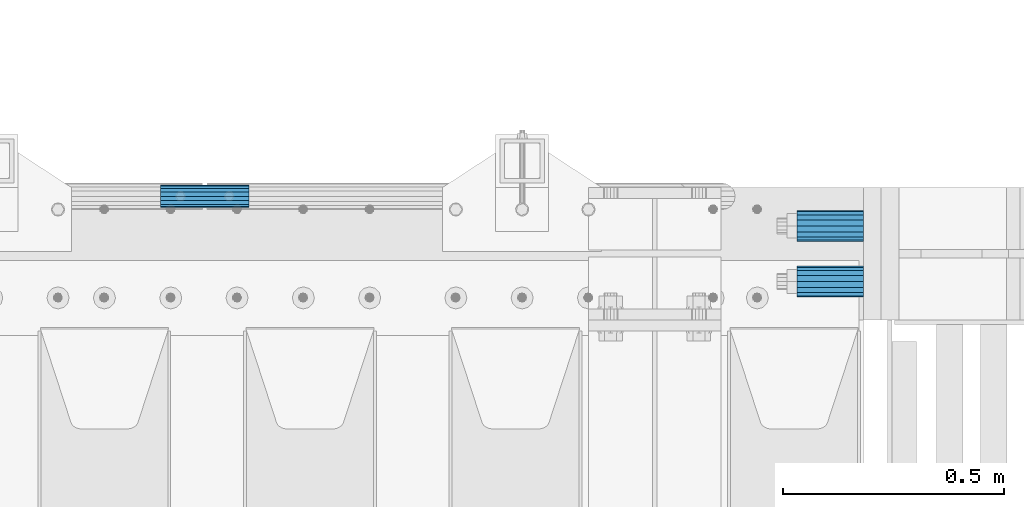
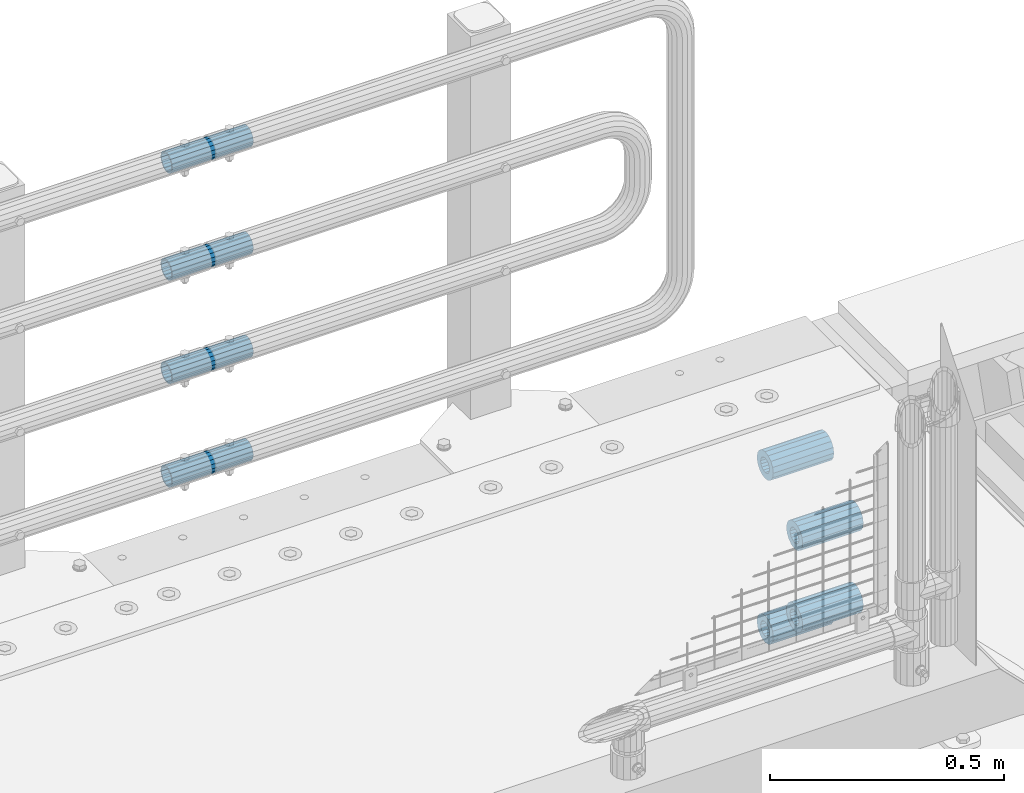
# One storey, part 174 of 247: 8 beams.
"""IFC2X3 building model written with IfcOpenShell, lengths in millimetres."""

from ifc_helpers import new_model, si_unit, frame, origin_with_axes, place, context, subcontext, project, spatial, faceted_brep, material, type_object, element, save


model = new_model("IFC2X3")

# Units and contexts
model_context = context("Model", 3, precision=1e-05, world=origin_with_axes())
body_context = subcontext(model_context, "Body", "Model", "MODEL_VIEW")
ifc_project = project(units=[si_unit("LENGTHUNIT", "METRE", prefix="MILLI"), si_unit("AREAUNIT", "SQUARE_METRE"), si_unit("VOLUMEUNIT", "CUBIC_METRE"), si_unit("MASSUNIT", "GRAM", prefix="KILO"), si_unit("TIMEUNIT", "SECOND"), si_unit("PLANEANGLEUNIT", "RADIAN"), si_unit("SOLIDANGLEUNIT", "STERADIAN"), si_unit("THERMODYNAMICTEMPERATUREUNIT", "DEGREE_CELSIUS"), si_unit("LUMINOUSINTENSITYUNIT", "LUMEN")], contexts=[model_context])

# Site, building, storey
site_placement = place(None, origin_with_axes())
site = spatial("IfcSite", under=ifc_project, at=site_placement, CompositionType="ELEMENT")
building_placement = place(site_placement, origin_with_axes())
building = spatial("IfcBuilding", under=site, at=building_placement, Name="Standard", CompositionType="ELEMENT")
storey_placement = place(building_placement, origin_with_axes())
storey = spatial("IfcBuildingStorey", under=building, at=storey_placement, Name="Undefined", CompositionType="ELEMENT", Elevation=0.0)

# Beams
ifc_material = material()
beam_type_1 = type_object("IfcBeamType", PredefinedType="NOTDEFINED")
beam_1_placement = place(storey_placement, frame((16667.0, 8937.0, -606.0), z_axis=(0.0, 0.0, 1.0), x_axis=(1.0, 0.0, 0.0)))
element("IfcBeam", 1, at=beam_1_placement, inside=storey, type_object=beam_type_1, material=ifc_material, context=body_context, shape_type="Brep", body=[
    faceted_brep([(-1.3120632047503e-07, -18.9999999995497, -6.27005647402257e-09), (0.0, -17.5537111177146, 7.27098521493672), (150.0, -17.5537111177146, 7.27098521493672), (150.0, -19.0, 0.0), (0.0, -13.4350288425444, 13.4350288425444), (150.0, -13.4350288425444, 13.4350288425444), (0.0, -7.2709852149369, 17.5537111177144), (150.0, -7.2709852149369, 17.5537111177144), (-6.3396328187082e-09, 4.50427251053043e-10, 18.9999999937299), (150.0, 0.0, 19.0), (0.0, 7.2709852149369, 17.5537111177144), (150.0, 7.2709852149369, 17.5537111177144), (0.0, 13.4350288425444, 13.4350288425444), (150.0, 13.4350288425444, 13.4350288425444), (0.0, 17.5537111177146, 7.2709852149367), (150.0, 17.5537111177146, 7.2709852149367), (1.33208573060983e-07, 19.0000000004504, -6.27005647402257e-09), (150.0, 19.0, 0.0), (0.0, 17.5537111177146, -7.2709852149367), (150.0, 17.5537111177146, -7.2709852149367), (0.0, 13.4350288425444, -13.4350288425444), (150.0, 13.4350288425444, -13.4350288425444), (0.0, 7.2709852149369, -17.5537111177144), (150.0, 7.2709852149369, -17.5537111177144), (8.3418854046613e-09, 4.50427251053043e-10, -19.0000000062682), (150.0, 0.0, -19.0), (0.0, -7.2709852149369, -17.5537111177144), (150.0, -7.2709852149369, -17.5537111177144), (0.0, -13.4350288425444, -13.4350288425444), (150.0, -13.4350288425444, -13.4350288425444), (0.0, -17.5537111177146, -7.2709852149367), (150.0, -17.5537111177146, -7.2709852149367), (0.0, -35.0, 0.0), (0.0, -32.335783637895, -13.3939201327782), (150.0, -32.335783637895, -13.3939201327782), (150.0, -35.0, 0.0), (0.0, -24.7487373415292, -24.7487373415291), (150.0, -24.7487373415293, -24.7487373415292), (0.0, -13.3939201327781, -32.335783637895), (150.0, -13.393920132778, -32.335783637895), (0.0, 0.0, -35.0000000000001), (150.0, 0.0, -35.0), (0.0, 13.3939201327782, -32.335783637895), (150.0, 13.393920132778, -32.335783637895), (0.0, 24.7487373415292, -24.7487373415291), (150.0, 24.7487373415293, -24.7487373415292), (0.0, 32.335783637895, -13.3939201327782), (150.0, 32.335783637895, -13.3939201327781), (0.0, 35.0, 0.0), (150.0, 35.0, 0.0), (0.0, 32.335783637895, 13.3939201327781), (150.0, 32.335783637895, 13.3939201327781), (0.0, 24.7487373415292, 24.748737341529), (150.0, 24.7487373415293, 24.7487373415292), (0.0, 13.3939201327781, 32.335783637895), (150.0, 13.393920132778, 32.335783637895), (0.0, 0.0, 35.0), (150.0, 0.0, 35.0), (0.0, -13.3939201327781, 32.335783637895), (150.0, -13.393920132778, 32.335783637895), (0.0, -24.7487373415292, 24.748737341529), (150.0, -24.7487373415293, 24.7487373415292), (0.0, -32.335783637895, 13.3939201327781), (150.0, -32.335783637895, 13.3939201327781)], [[[0, 1, 2, 3]], [[1, 4, 5, 2]], [[4, 6, 7, 5]], [[6, 8, 9, 7]], [[8, 10, 11, 9]], [[10, 12, 13, 11]], [[12, 14, 15, 13]], [[14, 16, 17, 15]], [[16, 18, 19, 17]], [[18, 20, 21, 19]], [[20, 22, 23, 21]], [[22, 24, 25, 23]], [[24, 26, 27, 25]], [[26, 28, 29, 27]], [[28, 30, 31, 29]], [[30, 0, 3, 31]], [[32, 33, 34, 35]], [[33, 36, 37, 34]], [[36, 38, 39, 37]], [[38, 40, 41, 39]], [[40, 42, 43, 41]], [[42, 44, 45, 43]], [[44, 46, 47, 45]], [[46, 48, 49, 47]], [[48, 50, 51, 49]], [[50, 52, 53, 51]], [[52, 54, 55, 53]], [[54, 56, 57, 55]], [[56, 58, 59, 57]], [[58, 60, 61, 59]], [[60, 62, 63, 61]], [[62, 32, 35, 63]], [[37, 39, 41, 43, 45, 47, 49, 51, 53, 55, 57, 59, 61, 63, 35, 34], [5, 7, 9, 11, 13, 15, 17, 19, 21, 23, 25, 27, 29, 31, 3, 2]], [[62, 60, 58, 56, 54, 52, 50, 48, 46, 44, 42, 40, 38, 36, 33, 32], [30, 28, 26, 24, 22, 20, 18, 16, 14, 12, 10, 8, 6, 4, 1, 0]]]),
])
beam_2_placement = place(storey_placement, frame((16667.0, 8937.0, -392.0), z_axis=(0.0, 0.0, 1.0), x_axis=(1.0, 0.0, 0.0)))
element("IfcBeam", 2, at=beam_2_placement, inside=storey, type_object=beam_type_1, material=ifc_material, context=body_context, shape_type="Brep", body=[
    faceted_brep([(-1.3120632047503e-07, -18.9999999995497, -6.27005647402257e-09), (0.0, -17.5537111177146, 7.27098521493672), (150.0, -17.5537111177146, 7.27098521493672), (150.0, -19.0, 0.0), (0.0, -13.4350288425444, 13.4350288425444), (150.0, -13.4350288425444, 13.4350288425444), (0.0, -7.2709852149369, 17.5537111177144), (150.0, -7.2709852149369, 17.5537111177144), (-6.3396328187082e-09, 4.50427251053043e-10, 18.9999999937299), (150.0, 0.0, 19.0), (0.0, 7.2709852149369, 17.5537111177144), (150.0, 7.2709852149369, 17.5537111177144), (0.0, 13.4350288425444, 13.4350288425444), (150.0, 13.4350288425444, 13.4350288425444), (0.0, 17.5537111177146, 7.2709852149367), (150.0, 17.5537111177146, 7.2709852149367), (1.33208573060983e-07, 19.0000000004504, -6.27005647402257e-09), (150.0, 19.0, 0.0), (0.0, 17.5537111177146, -7.2709852149367), (150.0, 17.5537111177146, -7.2709852149367), (0.0, 13.4350288425444, -13.4350288425444), (150.0, 13.4350288425444, -13.4350288425444), (0.0, 7.2709852149369, -17.5537111177144), (150.0, 7.2709852149369, -17.5537111177144), (8.3418854046613e-09, 4.50427251053043e-10, -19.0000000062682), (150.0, 0.0, -19.0), (0.0, -7.2709852149369, -17.5537111177144), (150.0, -7.2709852149369, -17.5537111177144), (0.0, -13.4350288425444, -13.4350288425444), (150.0, -13.4350288425444, -13.4350288425444), (0.0, -17.5537111177146, -7.2709852149367), (150.0, -17.5537111177146, -7.2709852149367), (0.0, -35.0, 0.0), (0.0, -32.335783637895, -13.3939201327782), (150.0, -32.335783637895, -13.3939201327782), (150.0, -35.0, 0.0), (0.0, -24.7487373415292, -24.7487373415291), (150.0, -24.7487373415293, -24.7487373415292), (0.0, -13.3939201327781, -32.335783637895), (150.0, -13.393920132778, -32.335783637895), (0.0, 0.0, -35.0000000000001), (150.0, 0.0, -35.0), (0.0, 13.3939201327782, -32.335783637895), (150.0, 13.393920132778, -32.335783637895), (0.0, 24.7487373415292, -24.7487373415291), (150.0, 24.7487373415293, -24.7487373415292), (0.0, 32.335783637895, -13.3939201327782), (150.0, 32.335783637895, -13.3939201327781), (0.0, 35.0, 0.0), (150.0, 35.0, 0.0), (0.0, 32.335783637895, 13.3939201327781), (150.0, 32.335783637895, 13.3939201327781), (0.0, 24.7487373415292, 24.748737341529), (150.0, 24.7487373415293, 24.7487373415292), (0.0, 13.3939201327781, 32.335783637895), (150.0, 13.393920132778, 32.335783637895), (0.0, 0.0, 35.0), (150.0, 0.0, 35.0), (0.0, -13.3939201327781, 32.335783637895), (150.0, -13.393920132778, 32.335783637895), (0.0, -24.7487373415292, 24.748737341529), (150.0, -24.7487373415293, 24.7487373415292), (0.0, -32.335783637895, 13.3939201327781), (150.0, -32.335783637895, 13.3939201327781)], [[[0, 1, 2, 3]], [[1, 4, 5, 2]], [[4, 6, 7, 5]], [[6, 8, 9, 7]], [[8, 10, 11, 9]], [[10, 12, 13, 11]], [[12, 14, 15, 13]], [[14, 16, 17, 15]], [[16, 18, 19, 17]], [[18, 20, 21, 19]], [[20, 22, 23, 21]], [[22, 24, 25, 23]], [[24, 26, 27, 25]], [[26, 28, 29, 27]], [[28, 30, 31, 29]], [[30, 0, 3, 31]], [[32, 33, 34, 35]], [[33, 36, 37, 34]], [[36, 38, 39, 37]], [[38, 40, 41, 39]], [[40, 42, 43, 41]], [[42, 44, 45, 43]], [[44, 46, 47, 45]], [[46, 48, 49, 47]], [[48, 50, 51, 49]], [[50, 52, 53, 51]], [[52, 54, 55, 53]], [[54, 56, 57, 55]], [[56, 58, 59, 57]], [[58, 60, 61, 59]], [[60, 62, 63, 61]], [[62, 32, 35, 63]], [[37, 39, 41, 43, 45, 47, 49, 51, 53, 55, 57, 59, 61, 63, 35, 34], [5, 7, 9, 11, 13, 15, 17, 19, 21, 23, 25, 27, 29, 31, 3, 2]], [[62, 60, 58, 56, 54, 52, 50, 48, 46, 44, 42, 40, 38, 36, 33, 32], [30, 28, 26, 24, 22, 20, 18, 16, 14, 12, 10, 8, 6, 4, 1, 0]]]),
])
beam_3_placement = place(storey_placement, frame((16667.0, 9063.0, -285.0), z_axis=(0.0, 0.0, 1.0), x_axis=(1.0, 0.0, 0.0)))
element("IfcBeam", 3, at=beam_3_placement, inside=storey, type_object=beam_type_1, material=ifc_material, context=body_context, shape_type="Brep", body=[
    faceted_brep([(-1.3120632047503e-07, -18.9999999995497, -6.27005647402257e-09), (0.0, -17.5537111177146, 7.27098521493672), (150.0, -17.5537111177146, 7.27098521493672), (150.0, -19.0, 0.0), (0.0, -13.4350288425444, 13.4350288425444), (150.0, -13.4350288425444, 13.4350288425444), (0.0, -7.2709852149369, 17.5537111177144), (150.0, -7.2709852149369, 17.5537111177144), (-6.3396328187082e-09, 4.50427251053043e-10, 18.9999999937299), (150.0, 0.0, 19.0), (0.0, 7.2709852149369, 17.5537111177144), (150.0, 7.2709852149369, 17.5537111177144), (0.0, 13.4350288425444, 13.4350288425444), (150.0, 13.4350288425444, 13.4350288425444), (0.0, 17.5537111177146, 7.2709852149367), (150.0, 17.5537111177146, 7.2709852149367), (1.33208573060983e-07, 19.0000000004504, -6.27005647402257e-09), (150.0, 19.0, 0.0), (0.0, 17.5537111177146, -7.2709852149367), (150.0, 17.5537111177146, -7.2709852149367), (0.0, 13.4350288425444, -13.4350288425444), (150.0, 13.4350288425444, -13.4350288425444), (0.0, 7.2709852149369, -17.5537111177144), (150.0, 7.2709852149369, -17.5537111177144), (8.3418854046613e-09, 4.50427251053043e-10, -19.0000000062682), (150.0, 0.0, -19.0), (0.0, -7.2709852149369, -17.5537111177144), (150.0, -7.2709852149369, -17.5537111177144), (0.0, -13.4350288425444, -13.4350288425444), (150.0, -13.4350288425444, -13.4350288425444), (0.0, -17.5537111177146, -7.2709852149367), (150.0, -17.5537111177146, -7.2709852149367), (0.0, -35.0, 0.0), (0.0, -32.335783637895, -13.3939201327782), (150.0, -32.335783637895, -13.3939201327782), (150.0, -35.0, 0.0), (0.0, -24.7487373415292, -24.7487373415291), (150.0, -24.7487373415293, -24.7487373415292), (0.0, -13.3939201327781, -32.335783637895), (150.0, -13.393920132778, -32.335783637895), (0.0, 0.0, -35.0000000000001), (150.0, 0.0, -35.0), (0.0, 13.3939201327782, -32.335783637895), (150.0, 13.393920132778, -32.335783637895), (0.0, 24.7487373415292, -24.7487373415291), (150.0, 24.7487373415293, -24.7487373415292), (0.0, 32.335783637895, -13.3939201327782), (150.0, 32.335783637895, -13.3939201327781), (0.0, 35.0, 0.0), (150.0, 35.0, 0.0), (0.0, 32.335783637895, 13.3939201327781), (150.0, 32.335783637895, 13.3939201327781), (0.0, 24.7487373415292, 24.748737341529), (150.0, 24.7487373415293, 24.7487373415292), (0.0, 13.3939201327781, 32.335783637895), (150.0, 13.393920132778, 32.335783637895), (0.0, 0.0, 35.0), (150.0, 0.0, 35.0), (0.0, -13.3939201327781, 32.335783637895), (150.0, -13.393920132778, 32.335783637895), (0.0, -24.7487373415292, 24.748737341529), (150.0, -24.7487373415293, 24.7487373415292), (0.0, -32.335783637895, 13.3939201327781), (150.0, -32.335783637895, 13.3939201327781)], [[[0, 1, 2, 3]], [[1, 4, 5, 2]], [[4, 6, 7, 5]], [[6, 8, 9, 7]], [[8, 10, 11, 9]], [[10, 12, 13, 11]], [[12, 14, 15, 13]], [[14, 16, 17, 15]], [[16, 18, 19, 17]], [[18, 20, 21, 19]], [[20, 22, 23, 21]], [[22, 24, 25, 23]], [[24, 26, 27, 25]], [[26, 28, 29, 27]], [[28, 30, 31, 29]], [[30, 0, 3, 31]], [[32, 33, 34, 35]], [[33, 36, 37, 34]], [[36, 38, 39, 37]], [[38, 40, 41, 39]], [[40, 42, 43, 41]], [[42, 44, 45, 43]], [[44, 46, 47, 45]], [[46, 48, 49, 47]], [[48, 50, 51, 49]], [[50, 52, 53, 51]], [[52, 54, 55, 53]], [[54, 56, 57, 55]], [[56, 58, 59, 57]], [[58, 60, 61, 59]], [[60, 62, 63, 61]], [[62, 32, 35, 63]], [[37, 39, 41, 43, 45, 47, 49, 51, 53, 55, 57, 59, 61, 63, 35, 34], [5, 7, 9, 11, 13, 15, 17, 19, 21, 23, 25, 27, 29, 31, 3, 2]], [[62, 60, 58, 56, 54, 52, 50, 48, 46, 44, 42, 40, 38, 36, 33, 32], [30, 28, 26, 24, 22, 20, 18, 16, 14, 12, 10, 8, 6, 4, 1, 0]]]),
])
beam_4_placement = place(storey_placement, frame((16667.0, 9063.0, -713.0), z_axis=(0.0, 0.0, 1.0), x_axis=(1.0, 0.0, 0.0)))
element("IfcBeam", 4, at=beam_4_placement, inside=storey, type_object=beam_type_1, material=ifc_material, context=body_context, shape_type="Brep", body=[
    faceted_brep([(-1.3120632047503e-07, -18.9999999995497, -6.27005647402257e-09), (0.0, -17.5537111177146, 7.27098521493672), (150.0, -17.5537111177146, 7.27098521493672), (150.0, -19.0, 0.0), (0.0, -13.4350288425444, 13.4350288425444), (150.0, -13.4350288425444, 13.4350288425444), (0.0, -7.2709852149369, 17.5537111177144), (150.0, -7.2709852149369, 17.5537111177144), (-6.3396328187082e-09, 4.50427251053043e-10, 18.9999999937299), (150.0, 0.0, 19.0), (0.0, 7.2709852149369, 17.5537111177144), (150.0, 7.2709852149369, 17.5537111177144), (0.0, 13.4350288425444, 13.4350288425444), (150.0, 13.4350288425444, 13.4350288425444), (0.0, 17.5537111177146, 7.2709852149367), (150.0, 17.5537111177146, 7.2709852149367), (1.33208573060983e-07, 19.0000000004504, -6.27005647402257e-09), (150.0, 19.0, 0.0), (0.0, 17.5537111177146, -7.2709852149367), (150.0, 17.5537111177146, -7.2709852149367), (0.0, 13.4350288425444, -13.4350288425444), (150.0, 13.4350288425444, -13.4350288425444), (0.0, 7.2709852149369, -17.5537111177144), (150.0, 7.2709852149369, -17.5537111177144), (8.3418854046613e-09, 4.50427251053043e-10, -19.0000000062682), (150.0, 0.0, -19.0), (0.0, -7.2709852149369, -17.5537111177144), (150.0, -7.2709852149369, -17.5537111177144), (0.0, -13.4350288425444, -13.4350288425444), (150.0, -13.4350288425444, -13.4350288425444), (0.0, -17.5537111177146, -7.2709852149367), (150.0, -17.5537111177146, -7.2709852149367), (0.0, -35.0, 0.0), (0.0, -32.335783637895, -13.3939201327782), (150.0, -32.335783637895, -13.3939201327782), (150.0, -35.0, 0.0), (0.0, -24.7487373415292, -24.7487373415291), (150.0, -24.7487373415293, -24.7487373415292), (0.0, -13.3939201327781, -32.335783637895), (150.0, -13.393920132778, -32.335783637895), (0.0, 0.0, -35.0000000000001), (150.0, 0.0, -35.0), (0.0, 13.3939201327782, -32.335783637895), (150.0, 13.393920132778, -32.335783637895), (0.0, 24.7487373415292, -24.7487373415291), (150.0, 24.7487373415293, -24.7487373415292), (0.0, 32.335783637895, -13.3939201327782), (150.0, 32.335783637895, -13.3939201327781), (0.0, 35.0, 0.0), (150.0, 35.0, 0.0), (0.0, 32.335783637895, 13.3939201327781), (150.0, 32.335783637895, 13.3939201327781), (0.0, 24.7487373415292, 24.748737341529), (150.0, 24.7487373415293, 24.7487373415292), (0.0, 13.3939201327781, 32.335783637895), (150.0, 13.393920132778, 32.335783637895), (0.0, 0.0, 35.0), (150.0, 0.0, 35.0), (0.0, -13.3939201327781, 32.335783637895), (150.0, -13.393920132778, 32.335783637895), (0.0, -24.7487373415292, 24.748737341529), (150.0, -24.7487373415293, 24.7487373415292), (0.0, -32.335783637895, 13.3939201327781), (150.0, -32.335783637895, 13.3939201327781)], [[[0, 1, 2, 3]], [[1, 4, 5, 2]], [[4, 6, 7, 5]], [[6, 8, 9, 7]], [[8, 10, 11, 9]], [[10, 12, 13, 11]], [[12, 14, 15, 13]], [[14, 16, 17, 15]], [[16, 18, 19, 17]], [[18, 20, 21, 19]], [[20, 22, 23, 21]], [[22, 24, 25, 23]], [[24, 26, 27, 25]], [[26, 28, 29, 27]], [[28, 30, 31, 29]], [[30, 0, 3, 31]], [[32, 33, 34, 35]], [[33, 36, 37, 34]], [[36, 38, 39, 37]], [[38, 40, 41, 39]], [[40, 42, 43, 41]], [[42, 44, 45, 43]], [[44, 46, 47, 45]], [[46, 48, 49, 47]], [[48, 50, 51, 49]], [[50, 52, 53, 51]], [[52, 54, 55, 53]], [[54, 56, 57, 55]], [[56, 58, 59, 57]], [[58, 60, 61, 59]], [[60, 62, 63, 61]], [[62, 32, 35, 63]], [[37, 39, 41, 43, 45, 47, 49, 51, 53, 55, 57, 59, 61, 63, 35, 34], [5, 7, 9, 11, 13, 15, 17, 19, 21, 23, 25, 27, 29, 31, 3, 2]], [[62, 60, 58, 56, 54, 52, 50, 48, 46, 44, 42, 40, 38, 36, 33, 32], [30, 28, 26, 24, 22, 20, 18, 16, 14, 12, 10, 8, 6, 4, 1, 0]]]),
])
beam_type_2 = type_object("IfcBeamType", PredefinedType="NOTDEFINED")
beam_5_placement = place(storey_placement, frame((15226.9975029999, 9129.8500000004, 419.849999999725), z_axis=(0.0, 0.0, 1.0), x_axis=(1.0, 0.0, 0.0)))
element("IfcBeam", 5, at=beam_5_placement, inside=storey, type_object=beam_type_2, material=ifc_material, context=body_context, shape_type="Brep", body=[
    faceted_brep([(0.0, -21.8999999999996, 0.0), (0.0, -20.232961761998, 8.38076716879547), (200.0, -20.232961761998, 8.38076716879547), (200.0, -21.8999999999996, 0.0), (0.0, -15.4856385079856, 15.4856385079854), (200.0, -15.4856385079856, 15.4856385079854), (0.0, -8.3807671687955, 20.2329617619972), (200.0, -8.3807671687955, 20.2329617619972), (0.0, 0.0, 21.9), (200.0, 0.0, 21.9), (0.0, 8.3807671687955, 20.2329617619972), (200.0, 8.3807671687955, 20.2329617619972), (0.0, 15.4856385079856, 15.4856385079854), (200.0, 15.4856385079856, 15.4856385079854), (0.0, 20.232961761998, 8.38076716879547), (200.0, 20.232961761998, 8.38076716879547), (0.0, 21.8999999999996, 0.0), (200.0, 21.8999999999996, 0.0), (0.0, 20.232961761998, -8.38076716879547), (200.0, 20.232961761998, -8.38076716879547), (0.0, 15.4856385079856, -15.4856385079854), (200.0, 15.4856385079856, -15.4856385079854), (0.0, 8.3807671687955, -20.2329617619972), (200.0, 8.3807671687955, -20.2329617619972), (0.0, 0.0, -21.9), (200.0, 0.0, -21.9), (0.0, -8.3807671687955, -20.2329617619972), (200.0, -8.3807671687955, -20.2329617619972), (0.0, -15.4856385079856, -15.4856385079854), (200.0, -15.4856385079856, -15.4856385079854), (0.0, -20.232961761998, -8.38076716879547), (200.0, -20.232961761998, -8.38076716879547), (0.0, -25.5, 0.0), (0.0, -23.5589280790373, -9.7584275253098), (200.0, -23.5589280790373, -9.7584275253098), (200.0, -25.5, 0.0), (0.0, -18.0312229202573, -18.031222920257), (200.0, -18.0312229202573, -18.031222920257), (0.0, -9.75842752531025, -23.5589280790378), (200.0, -9.75842752531025, -23.5589280790378), (0.0, 0.0, -25.5), (200.0, 0.0, -25.5), (0.0, 9.75842752531025, -23.5589280790378), (200.0, 9.75842752531025, -23.5589280790378), (0.0, 18.0312229202573, -18.031222920257), (200.0, 18.0312229202573, -18.031222920257), (0.0, 23.5589280790373, -9.7584275253098), (200.0, 23.5589280790373, -9.7584275253098), (0.0, 25.5, 0.0), (200.0, 25.5, 0.0), (0.0, 23.5589280790373, 9.7584275253098), (200.0, 23.5589280790373, 9.7584275253098), (0.0, 18.0312229202573, 18.031222920257), (200.0, 18.0312229202573, 18.031222920257), (0.0, 9.75842752531025, 23.5589280790378), (200.0, 9.75842752531025, 23.5589280790378), (0.0, 0.0, 25.5), (200.0, 0.0, 25.5), (0.0, -9.75842752531025, 23.5589280790378), (200.0, -9.75842752531025, 23.5589280790378), (0.0, -18.0312229202573, 18.031222920257), (200.0, -18.0312229202573, 18.031222920257), (0.0, -23.5589280790373, 9.7584275253098), (200.0, -23.5589280790373, 9.7584275253098)], [[[0, 1, 2, 3]], [[1, 4, 5, 2]], [[4, 6, 7, 5]], [[6, 8, 9, 7]], [[8, 10, 11, 9]], [[10, 12, 13, 11]], [[12, 14, 15, 13]], [[14, 16, 17, 15]], [[16, 18, 19, 17]], [[18, 20, 21, 19]], [[20, 22, 23, 21]], [[22, 24, 25, 23]], [[24, 26, 27, 25]], [[26, 28, 29, 27]], [[28, 30, 31, 29]], [[30, 0, 3, 31]], [[32, 33, 34, 35]], [[33, 36, 37, 34]], [[36, 38, 39, 37]], [[38, 40, 41, 39]], [[40, 42, 43, 41]], [[42, 44, 45, 43]], [[44, 46, 47, 45]], [[46, 48, 49, 47]], [[48, 50, 51, 49]], [[50, 52, 53, 51]], [[52, 54, 55, 53]], [[54, 56, 57, 55]], [[56, 58, 59, 57]], [[58, 60, 61, 59]], [[60, 62, 63, 61]], [[62, 32, 35, 63]], [[37, 39, 41, 43, 45, 47, 49, 51, 53, 55, 57, 59, 61, 63, 35, 34], [5, 7, 9, 11, 13, 15, 17, 19, 21, 23, 25, 27, 29, 31, 3, 2]], [[62, 60, 58, 56, 54, 52, 50, 48, 46, 44, 42, 40, 38, 36, 33, 32], [30, 28, 26, 24, 22, 20, 18, 16, 14, 12, 10, 8, 6, 4, 1, 0]]]),
])
beam_6_placement = place(storey_placement, frame((15226.9975029999, 9129.8500000004, 149.849999999725), z_axis=(0.0, 0.0, 1.0), x_axis=(1.0, 0.0, 0.0)))
element("IfcBeam", 6, at=beam_6_placement, inside=storey, type_object=beam_type_2, material=ifc_material, context=body_context, shape_type="Brep", body=[
    faceted_brep([(0.0, -21.8999999999996, 0.0), (0.0, -20.232961761998, 8.38076716879547), (200.0, -20.232961761998, 8.38076716879547), (200.0, -21.8999999999996, 0.0), (0.0, -15.4856385079856, 15.4856385079854), (200.0, -15.4856385079856, 15.4856385079854), (0.0, -8.3807671687955, 20.2329617619972), (200.0, -8.3807671687955, 20.2329617619972), (0.0, 0.0, 21.9), (200.0, 0.0, 21.9), (0.0, 8.3807671687955, 20.2329617619972), (200.0, 8.3807671687955, 20.2329617619972), (0.0, 15.4856385079856, 15.4856385079854), (200.0, 15.4856385079856, 15.4856385079854), (0.0, 20.232961761998, 8.38076716879547), (200.0, 20.232961761998, 8.38076716879547), (0.0, 21.8999999999996, 0.0), (200.0, 21.8999999999996, 0.0), (0.0, 20.232961761998, -8.38076716879547), (200.0, 20.232961761998, -8.38076716879547), (0.0, 15.4856385079856, -15.4856385079854), (200.0, 15.4856385079856, -15.4856385079854), (0.0, 8.3807671687955, -20.2329617619972), (200.0, 8.3807671687955, -20.2329617619972), (0.0, 0.0, -21.9), (200.0, 0.0, -21.9), (0.0, -8.3807671687955, -20.2329617619972), (200.0, -8.3807671687955, -20.2329617619972), (0.0, -15.4856385079856, -15.4856385079854), (200.0, -15.4856385079856, -15.4856385079854), (0.0, -20.232961761998, -8.38076716879547), (200.0, -20.232961761998, -8.38076716879547), (0.0, -25.5, 0.0), (0.0, -23.5589280790373, -9.7584275253098), (200.0, -23.5589280790373, -9.7584275253098), (200.0, -25.5, 0.0), (0.0, -18.0312229202573, -18.031222920257), (200.0, -18.0312229202573, -18.031222920257), (0.0, -9.75842752531025, -23.5589280790378), (200.0, -9.75842752531025, -23.5589280790378), (0.0, 0.0, -25.5), (200.0, 0.0, -25.5), (0.0, 9.75842752531025, -23.5589280790378), (200.0, 9.75842752531025, -23.5589280790378), (0.0, 18.0312229202573, -18.031222920257), (200.0, 18.0312229202573, -18.031222920257), (0.0, 23.5589280790373, -9.7584275253098), (200.0, 23.5589280790373, -9.7584275253098), (0.0, 25.5, 0.0), (200.0, 25.5, 0.0), (0.0, 23.5589280790373, 9.7584275253098), (200.0, 23.5589280790373, 9.7584275253098), (0.0, 18.0312229202573, 18.031222920257), (200.0, 18.0312229202573, 18.031222920257), (0.0, 9.75842752531025, 23.5589280790378), (200.0, 9.75842752531025, 23.5589280790378), (0.0, 0.0, 25.5), (200.0, 0.0, 25.5), (0.0, -9.75842752531025, 23.5589280790378), (200.0, -9.75842752531025, 23.5589280790378), (0.0, -18.0312229202573, 18.031222920257), (200.0, -18.0312229202573, 18.031222920257), (0.0, -23.5589280790373, 9.7584275253098), (200.0, -23.5589280790373, 9.7584275253098)], [[[0, 1, 2, 3]], [[1, 4, 5, 2]], [[4, 6, 7, 5]], [[6, 8, 9, 7]], [[8, 10, 11, 9]], [[10, 12, 13, 11]], [[12, 14, 15, 13]], [[14, 16, 17, 15]], [[16, 18, 19, 17]], [[18, 20, 21, 19]], [[20, 22, 23, 21]], [[22, 24, 25, 23]], [[24, 26, 27, 25]], [[26, 28, 29, 27]], [[28, 30, 31, 29]], [[30, 0, 3, 31]], [[32, 33, 34, 35]], [[33, 36, 37, 34]], [[36, 38, 39, 37]], [[38, 40, 41, 39]], [[40, 42, 43, 41]], [[42, 44, 45, 43]], [[44, 46, 47, 45]], [[46, 48, 49, 47]], [[48, 50, 51, 49]], [[50, 52, 53, 51]], [[52, 54, 55, 53]], [[54, 56, 57, 55]], [[56, 58, 59, 57]], [[58, 60, 61, 59]], [[60, 62, 63, 61]], [[62, 32, 35, 63]], [[37, 39, 41, 43, 45, 47, 49, 51, 53, 55, 57, 59, 61, 63, 35, 34], [5, 7, 9, 11, 13, 15, 17, 19, 21, 23, 25, 27, 29, 31, 3, 2]], [[62, 60, 58, 56, 54, 52, 50, 48, 46, 44, 42, 40, 38, 36, 33, 32], [30, 28, 26, 24, 22, 20, 18, 16, 14, 12, 10, 8, 6, 4, 1, 0]]]),
])
beam_7_placement = place(storey_placement, frame((15226.9975029999, 9129.8500000004, 689.849999999725), z_axis=(0.0, 0.0, 1.0), x_axis=(1.0, 0.0, 0.0)))
element("IfcBeam", 7, at=beam_7_placement, inside=storey, type_object=beam_type_2, material=ifc_material, context=body_context, shape_type="Brep", body=[
    faceted_brep([(0.0, -21.8999999999996, 0.0), (0.0, -20.232961761998, 8.38076716879547), (200.0, -20.232961761998, 8.38076716879547), (200.0, -21.8999999999996, 0.0), (0.0, -15.4856385079856, 15.4856385079854), (200.0, -15.4856385079856, 15.4856385079854), (0.0, -8.3807671687955, 20.2329617619972), (200.0, -8.3807671687955, 20.2329617619972), (0.0, 0.0, 21.9), (200.0, 0.0, 21.9), (0.0, 8.3807671687955, 20.2329617619972), (200.0, 8.3807671687955, 20.2329617619972), (0.0, 15.4856385079856, 15.4856385079854), (200.0, 15.4856385079856, 15.4856385079854), (0.0, 20.232961761998, 8.38076716879547), (200.0, 20.232961761998, 8.38076716879547), (0.0, 21.8999999999996, 0.0), (200.0, 21.8999999999996, 0.0), (0.0, 20.232961761998, -8.38076716879547), (200.0, 20.232961761998, -8.38076716879547), (0.0, 15.4856385079856, -15.4856385079854), (200.0, 15.4856385079856, -15.4856385079854), (0.0, 8.3807671687955, -20.2329617619972), (200.0, 8.3807671687955, -20.2329617619972), (0.0, 0.0, -21.9), (200.0, 0.0, -21.9), (0.0, -8.3807671687955, -20.2329617619972), (200.0, -8.3807671687955, -20.2329617619972), (0.0, -15.4856385079856, -15.4856385079854), (200.0, -15.4856385079856, -15.4856385079854), (0.0, -20.232961761998, -8.38076716879547), (200.0, -20.232961761998, -8.38076716879547), (0.0, -25.5, 0.0), (0.0, -23.5589280790373, -9.7584275253098), (200.0, -23.5589280790373, -9.7584275253098), (200.0, -25.5, 0.0), (0.0, -18.0312229202573, -18.031222920257), (200.0, -18.0312229202573, -18.031222920257), (0.0, -9.75842752531025, -23.5589280790378), (200.0, -9.75842752531025, -23.5589280790378), (0.0, 0.0, -25.5), (200.0, 0.0, -25.5), (0.0, 9.75842752531025, -23.5589280790378), (200.0, 9.75842752531025, -23.5589280790378), (0.0, 18.0312229202573, -18.031222920257), (200.0, 18.0312229202573, -18.031222920257), (0.0, 23.5589280790373, -9.7584275253098), (200.0, 23.5589280790373, -9.7584275253098), (0.0, 25.5, 0.0), (200.0, 25.5, 0.0), (0.0, 23.5589280790373, 9.7584275253098), (200.0, 23.5589280790373, 9.7584275253098), (0.0, 18.0312229202573, 18.031222920257), (200.0, 18.0312229202573, 18.031222920257), (0.0, 9.75842752531025, 23.5589280790378), (200.0, 9.75842752531025, 23.5589280790378), (0.0, 0.0, 25.5), (200.0, 0.0, 25.5), (0.0, -9.75842752531025, 23.5589280790378), (200.0, -9.75842752531025, 23.5589280790378), (0.0, -18.0312229202573, 18.031222920257), (200.0, -18.0312229202573, 18.031222920257), (0.0, -23.5589280790373, 9.7584275253098), (200.0, -23.5589280790373, 9.7584275253098)], [[[0, 1, 2, 3]], [[1, 4, 5, 2]], [[4, 6, 7, 5]], [[6, 8, 9, 7]], [[8, 10, 11, 9]], [[10, 12, 13, 11]], [[12, 14, 15, 13]], [[14, 16, 17, 15]], [[16, 18, 19, 17]], [[18, 20, 21, 19]], [[20, 22, 23, 21]], [[22, 24, 25, 23]], [[24, 26, 27, 25]], [[26, 28, 29, 27]], [[28, 30, 31, 29]], [[30, 0, 3, 31]], [[32, 33, 34, 35]], [[33, 36, 37, 34]], [[36, 38, 39, 37]], [[38, 40, 41, 39]], [[40, 42, 43, 41]], [[42, 44, 45, 43]], [[44, 46, 47, 45]], [[46, 48, 49, 47]], [[48, 50, 51, 49]], [[50, 52, 53, 51]], [[52, 54, 55, 53]], [[54, 56, 57, 55]], [[56, 58, 59, 57]], [[58, 60, 61, 59]], [[60, 62, 63, 61]], [[62, 32, 35, 63]], [[37, 39, 41, 43, 45, 47, 49, 51, 53, 55, 57, 59, 61, 63, 35, 34], [5, 7, 9, 11, 13, 15, 17, 19, 21, 23, 25, 27, 29, 31, 3, 2]], [[62, 60, 58, 56, 54, 52, 50, 48, 46, 44, 42, 40, 38, 36, 33, 32], [30, 28, 26, 24, 22, 20, 18, 16, 14, 12, 10, 8, 6, 4, 1, 0]]]),
])
beam_8_placement = place(storey_placement, frame((15226.9975029999, 9129.85000000046, 969.849999999725), z_axis=(0.0, 0.0, 1.0), x_axis=(1.0, 0.0, 0.0)))
element("IfcBeam", 8, at=beam_8_placement, inside=storey, type_object=beam_type_2, material=ifc_material, context=body_context, shape_type="Brep", body=[
    faceted_brep([(0.0, -21.8999999999996, 0.0), (0.0, -20.232961761998, 8.38076716879547), (200.0, -20.232961761998, 8.38076716879547), (200.0, -21.8999999999996, 0.0), (0.0, -15.4856385079856, 15.4856385079854), (200.0, -15.4856385079856, 15.4856385079854), (0.0, -8.3807671687955, 20.2329617619972), (200.0, -8.3807671687955, 20.2329617619972), (0.0, 0.0, 21.9), (200.0, 0.0, 21.9), (0.0, 8.3807671687955, 20.2329617619972), (200.0, 8.3807671687955, 20.2329617619972), (0.0, 15.4856385079856, 15.4856385079854), (200.0, 15.4856385079856, 15.4856385079854), (0.0, 20.232961761998, 8.38076716879547), (200.0, 20.232961761998, 8.38076716879547), (0.0, 21.8999999999996, 0.0), (200.0, 21.8999999999996, 0.0), (0.0, 20.232961761998, -8.38076716879547), (200.0, 20.232961761998, -8.38076716879547), (0.0, 15.4856385079856, -15.4856385079854), (200.0, 15.4856385079856, -15.4856385079854), (0.0, 8.3807671687955, -20.2329617619972), (200.0, 8.3807671687955, -20.2329617619972), (0.0, 0.0, -21.9), (200.0, 0.0, -21.9), (0.0, -8.3807671687955, -20.2329617619972), (200.0, -8.3807671687955, -20.2329617619972), (0.0, -15.4856385079856, -15.4856385079854), (200.0, -15.4856385079856, -15.4856385079854), (0.0, -20.232961761998, -8.38076716879547), (200.0, -20.232961761998, -8.38076716879547), (0.0, -25.5, 0.0), (0.0, -23.5589280790373, -9.7584275253098), (200.0, -23.5589280790373, -9.7584275253098), (200.0, -25.5, 0.0), (0.0, -18.0312229202573, -18.031222920257), (200.0, -18.0312229202573, -18.031222920257), (0.0, -9.75842752531025, -23.5589280790378), (200.0, -9.75842752531025, -23.5589280790378), (0.0, 0.0, -25.5), (200.0, 0.0, -25.5), (0.0, 9.75842752531025, -23.5589280790378), (200.0, 9.75842752531025, -23.5589280790378), (0.0, 18.0312229202573, -18.031222920257), (200.0, 18.0312229202573, -18.031222920257), (0.0, 23.5589280790373, -9.7584275253098), (200.0, 23.5589280790373, -9.7584275253098), (0.0, 25.5, 0.0), (200.0, 25.5, 0.0), (0.0, 23.5589280790373, 9.7584275253098), (200.0, 23.5589280790373, 9.7584275253098), (0.0, 18.0312229202573, 18.031222920257), (200.0, 18.0312229202573, 18.031222920257), (0.0, 9.75842752531025, 23.5589280790378), (200.0, 9.75842752531025, 23.5589280790378), (0.0, 0.0, 25.5), (200.0, 0.0, 25.5), (0.0, -9.75842752531025, 23.5589280790378), (200.0, -9.75842752531025, 23.5589280790378), (0.0, -18.0312229202573, 18.031222920257), (200.0, -18.0312229202573, 18.031222920257), (0.0, -23.5589280790373, 9.7584275253098), (200.0, -23.5589280790373, 9.7584275253098)], [[[0, 1, 2, 3]], [[1, 4, 5, 2]], [[4, 6, 7, 5]], [[6, 8, 9, 7]], [[8, 10, 11, 9]], [[10, 12, 13, 11]], [[12, 14, 15, 13]], [[14, 16, 17, 15]], [[16, 18, 19, 17]], [[18, 20, 21, 19]], [[20, 22, 23, 21]], [[22, 24, 25, 23]], [[24, 26, 27, 25]], [[26, 28, 29, 27]], [[28, 30, 31, 29]], [[30, 0, 3, 31]], [[32, 33, 34, 35]], [[33, 36, 37, 34]], [[36, 38, 39, 37]], [[38, 40, 41, 39]], [[40, 42, 43, 41]], [[42, 44, 45, 43]], [[44, 46, 47, 45]], [[46, 48, 49, 47]], [[48, 50, 51, 49]], [[50, 52, 53, 51]], [[52, 54, 55, 53]], [[54, 56, 57, 55]], [[56, 58, 59, 57]], [[58, 60, 61, 59]], [[60, 62, 63, 61]], [[62, 32, 35, 63]], [[37, 39, 41, 43, 45, 47, 49, 51, 53, 55, 57, 59, 61, 63, 35, 34], [5, 7, 9, 11, 13, 15, 17, 19, 21, 23, 25, 27, 29, 31, 3, 2]], [[62, 60, 58, 56, 54, 52, 50, 48, 46, 44, 42, 40, 38, 36, 33, 32], [30, 28, 26, 24, 22, 20, 18, 16, 14, 12, 10, 8, 6, 4, 1, 0]]]),
])

save(model, "model.ifc")
